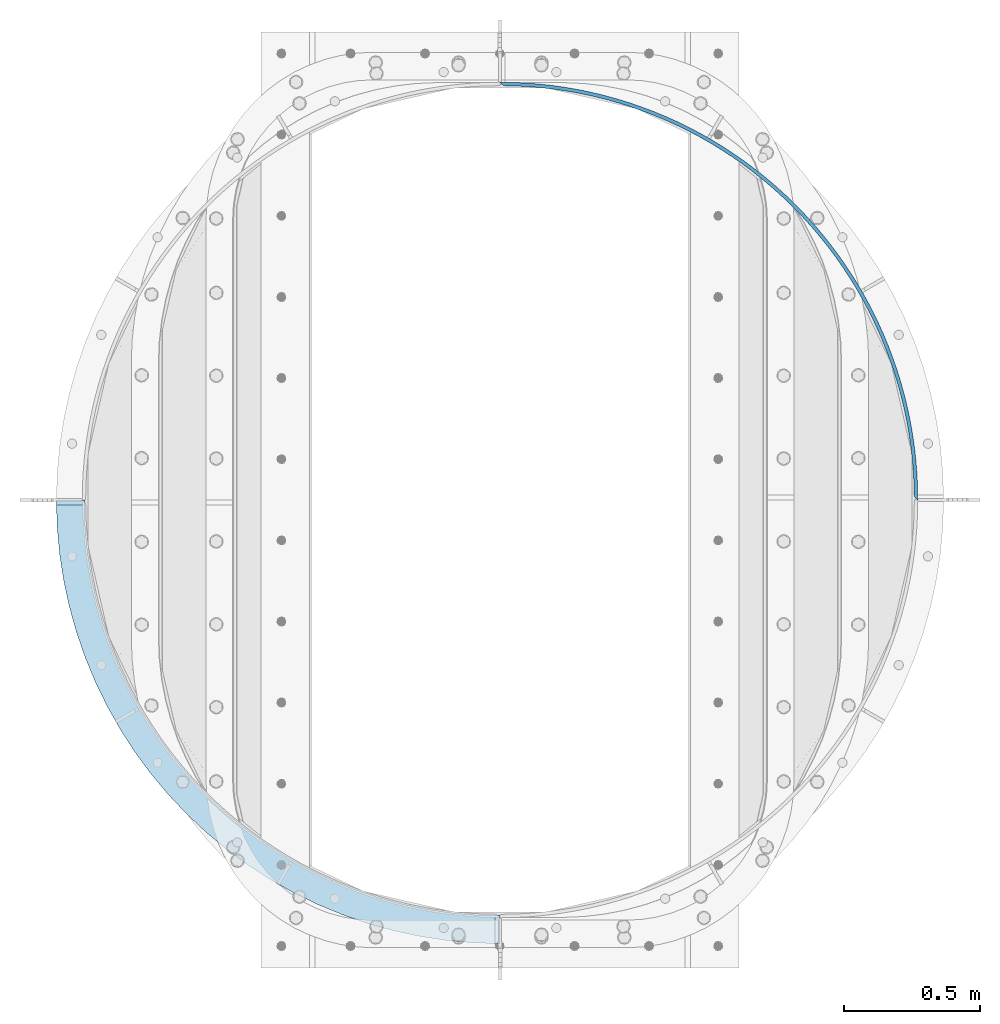
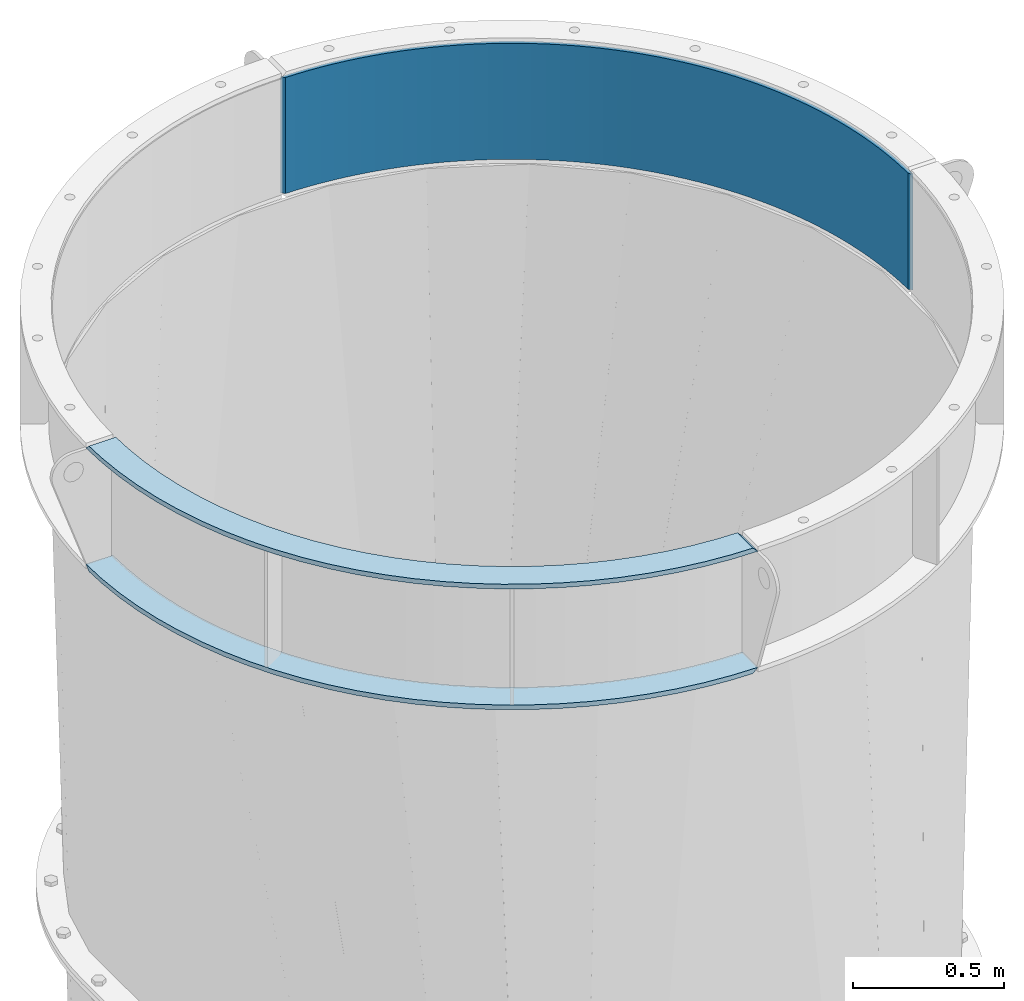
# One storey, part 9 of 15: 2 plates, 1 beam, 1 element without a shape of its own.
"""IFC2X3 building model written with IfcOpenShell, lengths in millimetres."""

from ifc_helpers import new_model, si_unit, frame, origin_with_axes, place, context, subcontext, project, spatial, faceted_brep, material, type_object, element, aggregate, save


model = new_model("IFC2X3")

# Units and contexts
model_context = context("Model", 3, precision=1e-05, world=origin_with_axes())
body_context = subcontext(model_context, "Body", "Model", "MODEL_VIEW")
ifc_project = project(units=[si_unit("LENGTHUNIT", "METRE", prefix="MILLI"), si_unit("AREAUNIT", "SQUARE_METRE"), si_unit("VOLUMEUNIT", "CUBIC_METRE"), si_unit("MASSUNIT", "GRAM", prefix="KILO"), si_unit("TIMEUNIT", "SECOND"), si_unit("PLANEANGLEUNIT", "RADIAN"), si_unit("SOLIDANGLEUNIT", "STERADIAN"), si_unit("THERMODYNAMICTEMPERATUREUNIT", "DEGREE_CELSIUS"), si_unit("LUMINOUSINTENSITYUNIT", "LUMEN")], contexts=[model_context])

# Site, building, storey
site_placement = place(None, origin_with_axes())
site = spatial("IfcSite", under=ifc_project, at=site_placement, CompositionType="ELEMENT")
building_placement = place(site_placement, origin_with_axes())
building = spatial("IfcBuilding", under=site, at=building_placement, Name="Undefined", CompositionType="ELEMENT")
storey_placement = place(building_placement, origin_with_axes())
storey = spatial("IfcBuildingStorey", under=building, at=storey_placement, Name="Undefined", CompositionType="ELEMENT", Elevation=0.0)

# Assembly, beam, plates
assembly_placement = place(storey_placement, origin_with_axes())
assembly = element("IfcElementAssembly", 1, at=assembly_placement, inside=storey, Name="TRANSITION", AssemblyPlace="NOTDEFINED", PredefinedType="RIGID_FRAME")
ifc_material = material(Name="STEEL/A36")
beam_type = type_object("IfcBeamType", PredefinedType="NOTDEFINED")
beam_placement = place(assembly_placement, frame((879.47500000022, 3251.20000000027, 6518.28), z_axis=(0.0, 0.0, 1.0), x_axis=(0.707106781186548, -0.707106781186548, 0.0)))
beam = element("IfcBeam", 2, at=beam_placement, type_object=beam_type, material=ifc_material, Name="PLATE", context=body_context, shape_type="Brep", body=[
    faceted_brep([(2168.73185323846, 4.4901280603583, 234.95), (2150.63139313598, 4.34796445618963, 234.95), (2150.63139313598, 4.34796445618963, -234.95), (2168.73185323846, 4.4901280603583, -234.95), (13.6103320421265, 4.34796445619054, 234.95), (-4.49012806053565, 4.49012806053361, 234.95), (-4.49012806053565, 4.49012806053361, -234.95), (13.6103320421265, 4.34796445619054, -234.95), (30.1773249082131, 38.0852271696592, 234.95), (30.1773249082131, 38.0852271696592, -234.95), (38.8710731535093, 28.8273256014088, -234.95), (38.8710731535093, 28.8273256014088, 234.95), (65.8829191459708, 70.5748181123124, 234.95), (65.8829191459708, 70.5748181123124, -234.95), (74.2815798355832, 61.0484075280069, -234.95), (74.2815798355832, 61.0484075280069, 234.95), (102.591417542014, 101.92683758475, 234.95), (102.591417542014, 101.92683758475, -234.95), (110.686702211824, 92.1413194014985, -234.95), (110.686702211824, 92.1413194014985, 234.95), (140.266593240295, 132.110344928926, 234.95), (140.266593240295, 132.110344928926, -234.95), (148.05051282169, 122.075376271756, -234.95), (148.05051282169, 122.075376271756, 234.95), (178.871265390981, 161.095552667193, 234.95), (178.871265390981, 161.095552667193, -234.95), (186.336138095097, 150.821036838632, -234.95), (186.336138095097, 150.821036838632, 234.95), (218.367335843456, 188.853855898938, 234.95), (218.367335843456, 188.853855898938, -234.95), (225.50579474218, 178.349932605652, -234.95), (225.50579474218, 178.349932605652, 234.95), (258.715826744602, 215.357860530173, 234.95), (258.715826744602, 215.357860530173, -234.95), (265.520827040837, 204.634895876298, -234.95), (265.520827040837, 204.634895876298, 234.95), (299.876919005232, 240.581410308193, 234.95), (299.876919005232, 240.581410308193, -234.95), (306.341744985264, 229.649986565244, -234.95), (306.341744985264, 229.649986565244, 234.95), (341.809991596724, 264.499612634644, 234.95), (341.809991596724, 264.499612634644, -234.95), (347.928263257818, 253.370517798088, -234.95), (347.928263257818, 253.370517798088, 234.95), (384.473661639071, 287.088863131509, 234.95), (384.473661639071, 287.088863131509, -234.95), (390.239340985765, 275.773080274318, -234.95), (390.239340985765, 275.773080274318, 234.95), (427.825825240789, 308.326868935782, 234.95), (427.825825240789, 308.326868935782, -234.95), (433.233222243668, 296.835565369465, -234.95), (433.233222243668, 296.835565369465, 234.95), (471.823699050373, 328.192670699828, 234.95), (471.823699050373, 328.192670699828, -234.95), (476.867477261437, 316.537186953643, -234.95), (476.867477261437, 316.537186953643, 234.95), (516.423862478301, 346.666663275734, 234.95), (516.423862478301, 346.666663275734, -234.95), (521.099044297397, 334.858501904954, -234.95), (521.099044297397, 334.858501904954, 234.95), (561.582300547911, 363.73061506322, 234.95), (561.582300547911, 363.73061506322, -234.95), (565.884272135028, 351.781429297502, -234.95), (565.884272135028, 351.781429297502, 234.95), (607.254447332874, 379.367686002027, 234.95), (607.254447332874, 379.367686002027, -234.95), (611.178963161437, 367.289268245079, -234.95), (611.178963161437, 367.289268245079, 234.95), (653.395229938378, 393.562444191024, 234.95), (653.395229938378, 393.562444191024, -234.95), (656.938416985078, 381.366714382928, -234.95), (656.938416985078, 381.366714382928, 234.95), (699.959112982635, 406.300881117635, 234.95), (699.959112982635, 406.300881117635, -234.95), (703.11747454963, 393.999874971302, -234.95), (703.11747454963, 393.999874971302, 234.95), (746.900143534807, 417.570425482542, 234.95), (746.900143534807, 417.570425482542, -234.95), (749.670562700545, 405.17628260592, -234.95), (749.670562700545, 405.17628260592, 234.95), (794.171996464998, 427.359955606045, 234.95), (794.171996464998, 427.359955606045, -234.95), (796.551739160238, 414.884907521791, -234.95), (796.551739160238, 414.884907521791, 234.95), (841.728020161566, 435.659810403817, 234.95), (841.728020161566, 435.659810403817, -234.95), (843.714737867578, 423.116168478259, -234.95), (843.714737867578, 423.116168478259, 234.95), (889.52128257063, 442.461798921226, 234.95), (889.52128257063, 442.461798921226, -234.95), (891.113014636898, 429.861942214533, -234.95), (891.113014636898, 429.861942214533, 234.95), (937.504617512343, 447.759208416819, 234.95), (937.504617512343, 447.759208416819, -234.95), (938.699793091489, 435.115571466361, -234.95), (938.699793091489, 435.115571466361, 234.95), (985.630671228216, 451.546810986989, 234.95), (985.630671228216, 451.546810986989, -234.95), (986.42811082624, 438.871871535951, -234.95), (986.42811082624, 438.871871535951, 234.95), (1033.85194911356, 453.820868725281, 234.95), (1033.85194911356, 453.820868725281, -234.95), (1034.25086575385, 441.127135408636, -234.95), (1034.25086575385, 441.127135408636, 234.95), (1082.12086258893, 454.579137411258, 234.95), (1082.12086258893, 454.579137411258, -234.95), (1082.12086258893, 441.879137411258, -234.95), (1082.12086258893, 441.879137411258, 234.95), (1130.3897760643, 453.820868725272, 234.95), (1130.3897760643, 453.820868725272, -234.95), (1129.99085942401, 441.127135408629, -234.95), (1129.99085942401, 441.127135408629, 234.95), (1178.61105394964, 451.546810986973, 234.95), (1178.61105394964, 451.546810986973, -234.95), (1177.81361435162, 438.871871535935, -234.95), (1177.81361435162, 438.871871535935, 234.95), (1226.73710766552, 447.759208416796, 234.95), (1226.73710766552, 447.759208416796, -234.95), (1225.54193208637, 435.115571466338, -234.95), (1225.54193208637, 435.115571466338, 234.95), (1274.72044260723, 442.461798921194, 234.95), (1274.72044260723, 442.461798921194, -234.95), (1273.12871054096, 429.861942214502, -234.95), (1273.12871054096, 429.861942214502, 234.95), (1322.51370501629, 435.659810403778, 234.95), (1322.51370501629, 435.659810403778, -234.95), (1320.52698731028, 423.116168478221, -234.95), (1320.52698731028, 423.116168478221, 234.95), (1370.06972871286, 427.359955605998, 234.95), (1370.06972871286, 427.359955605998, -234.95), (1367.68998601762, 414.884907521745, -234.95), (1367.68998601762, 414.884907521745, 234.95), (1417.34158164306, 417.570425482488, 234.95), (1417.34158164306, 417.570425482488, -234.95), (1414.57116247732, 405.176282605867, -234.95), (1414.57116247732, 405.176282605867, 234.95), (1464.28261219523, 406.300881117574, 234.95), (1464.28261219523, 406.300881117574, -234.95), (1461.12425062824, 393.999874971241, -234.95), (1461.12425062824, 393.999874971241, 234.95), (1510.84649523949, 393.562444190955, 234.95), (1510.84649523949, 393.562444190955, -234.95), (1507.30330819279, 381.36671438286, -234.95), (1507.30330819279, 381.36671438286, 234.95), (1556.98727784499, 379.36768600195, 234.95), (1556.98727784499, 379.36768600195, -234.95), (1553.06276201643, 367.289268245003, -234.95), (1553.06276201643, 367.289268245003, 234.95), (1602.65942462996, 363.730615063135, 234.95), (1602.65942462996, 363.730615063135, -234.95), (1598.35745304285, 351.781429297419, -234.95), (1598.35745304285, 351.781429297419, 234.95), (1647.81786269957, 346.666663275642, 234.95), (1647.81786269957, 346.666663275642, -234.95), (1643.14268088048, 334.858501904863, -234.95), (1643.14268088048, 334.858501904863, 234.95), (1692.4180261275, 328.192670699729, 234.95), (1692.4180261275, 328.192670699729, -234.95), (1687.37424791644, 316.537186953544, -234.95), (1687.37424791644, 316.537186953544, 234.95), (1736.41589993709, 308.326868935676, 234.95), (1736.41589993709, 308.326868935676, -234.95), (1731.00850293421, 296.835565369359, -234.95), (1731.00850293421, 296.835565369359, 234.95), (1779.76806353881, 287.088863131397, 234.95), (1779.76806353881, 287.088863131397, -234.95), (1774.00238419212, 275.773080274206, -234.95), (1774.00238419212, 275.773080274206, 234.95), (1822.43173358116, 264.499612634525, 234.95), (1822.43173358116, 264.499612634525, -234.95), (1816.31346192007, 253.370517797969, -234.95), (1816.31346192007, 253.370517797969, 234.95), (1864.36480617266, 240.581410308067, 234.95), (1864.36480617266, 240.581410308067, -234.95), (1857.89998019263, 229.649986565118, -234.95), (1857.89998019263, 229.649986565118, 234.95), (1905.52589843329, 215.357860530039, 234.95), (1905.52589843329, 215.357860530039, -234.95), (1898.72089813706, 204.634895876166, -234.95), (1898.72089813706, 204.634895876166, 234.95), (1945.87438933444, 188.853855898798, 234.95), (1945.87438933444, 188.853855898798, -234.95), (1938.73593043572, 178.349932605514, -234.95), (1938.73593043572, 178.349932605514, 234.95), (1985.37045978692, 161.095552667047, 234.95), (1985.37045978692, 161.095552667047, -234.95), (1977.90558708281, 150.821036838488, -234.95), (1977.90558708281, 150.821036838488, 234.95), (2023.97513193761, 132.110344928774, 234.95), (2023.97513193761, 132.110344928774, -234.95), (2016.19121235622, 122.075376271606, -234.95), (2016.19121235622, 122.075376271606, 234.95), (2061.6503076359, 101.926837584591, 234.95), (2061.6503076359, 101.926837584591, -234.95), (2053.55502296609, 92.1413194013419, -234.95), (2053.55502296609, 92.1413194013419, 234.95), (2098.35880603195, 70.5748181121483, 234.95), (2098.35880603195, 70.5748181121483, -234.95), (2089.96014534234, 61.0484075278443, -234.95), (2089.96014534234, 61.0484075278443, 234.95), (2134.06440026971, 38.0852271694891, 234.95), (2134.06440026971, 38.0852271694891, -234.95), (2125.37065202442, 28.8273256012403, -234.95), (2125.37065202442, 28.8273256012403, 234.95)], [[[0, 1, 2, 3]], [[4, 5, 6, 7]], [[6, 5, 8, 9]], [[10, 11, 4, 7]], [[9, 8, 12, 13]], [[11, 10, 14, 15]], [[13, 12, 16, 17]], [[15, 14, 18, 19]], [[17, 16, 20, 21]], [[19, 18, 22, 23]], [[21, 20, 24, 25]], [[23, 22, 26, 27]], [[25, 24, 28, 29]], [[27, 26, 30, 31]], [[29, 28, 32, 33]], [[31, 30, 34, 35]], [[33, 32, 36, 37]], [[35, 34, 38, 39]], [[37, 36, 40, 41]], [[39, 38, 42, 43]], [[41, 40, 44, 45]], [[43, 42, 46, 47]], [[45, 44, 48, 49]], [[47, 46, 50, 51]], [[49, 48, 52, 53]], [[51, 50, 54, 55]], [[53, 52, 56, 57]], [[55, 54, 58, 59]], [[57, 56, 60, 61]], [[59, 58, 62, 63]], [[61, 60, 64, 65]], [[63, 62, 66, 67]], [[65, 64, 68, 69]], [[67, 66, 70, 71]], [[69, 68, 72, 73]], [[71, 70, 74, 75]], [[73, 72, 76, 77]], [[75, 74, 78, 79]], [[77, 76, 80, 81]], [[79, 78, 82, 83]], [[81, 80, 84, 85]], [[83, 82, 86, 87]], [[85, 84, 88, 89]], [[87, 86, 90, 91]], [[89, 88, 92, 93]], [[91, 90, 94, 95]], [[93, 92, 96, 97]], [[95, 94, 98, 99]], [[97, 96, 100, 101]], [[99, 98, 102, 103]], [[101, 100, 104, 105]], [[103, 102, 106, 107]], [[105, 104, 108, 109]], [[107, 106, 110, 111]], [[109, 108, 112, 113]], [[111, 110, 114, 115]], [[113, 112, 116, 117]], [[115, 114, 118, 119]], [[117, 116, 120, 121]], [[119, 118, 122, 123]], [[121, 120, 124, 125]], [[123, 122, 126, 127]], [[125, 124, 128, 129]], [[127, 126, 130, 131]], [[129, 128, 132, 133]], [[131, 130, 134, 135]], [[133, 132, 136, 137]], [[135, 134, 138, 139]], [[137, 136, 140, 141]], [[139, 138, 142, 143]], [[141, 140, 144, 145]], [[143, 142, 146, 147]], [[145, 144, 148, 149]], [[147, 146, 150, 151]], [[149, 148, 152, 153]], [[151, 150, 154, 155]], [[153, 152, 156, 157]], [[155, 154, 158, 159]], [[157, 156, 160, 161]], [[159, 158, 162, 163]], [[161, 160, 164, 165]], [[163, 162, 166, 167]], [[165, 164, 168, 169]], [[167, 166, 170, 171]], [[169, 168, 172, 173]], [[171, 170, 174, 175]], [[173, 172, 176, 177]], [[175, 174, 178, 179]], [[177, 176, 180, 181]], [[179, 178, 182, 183]], [[181, 180, 184, 185]], [[183, 182, 186, 187]], [[185, 184, 188, 189]], [[187, 186, 190, 191]], [[189, 188, 192, 193]], [[191, 190, 194, 195]], [[193, 192, 196, 197]], [[195, 194, 198, 199]], [[197, 196, 200, 201]], [[199, 198, 202, 203]], [[201, 200, 0, 3]], [[200, 196, 192, 188, 184, 180, 176, 172, 168, 164, 160, 156, 152, 148, 144, 140, 136, 132, 128, 124, 120, 116, 112, 108, 104, 100, 96, 92, 88, 84, 80, 76, 72, 68, 64, 60, 56, 52, 48, 44, 40, 36, 32, 28, 24, 20, 16, 12, 8, 5, 4, 11, 15, 19, 23, 27, 31, 35, 39, 43, 47, 51, 55, 59, 63, 67, 71, 75, 79, 83, 87, 91, 95, 99, 103, 107, 111, 115, 119, 123, 127, 131, 135, 139, 143, 147, 151, 155, 159, 163, 167, 171, 175, 179, 183, 187, 191, 195, 199, 203, 1, 0]], [[203, 202, 2, 1]], [[202, 198, 194, 190, 186, 182, 178, 174, 170, 166, 162, 158, 154, 150, 146, 142, 138, 134, 130, 126, 122, 118, 114, 110, 106, 102, 98, 94, 90, 86, 82, 78, 74, 70, 66, 62, 58, 54, 50, 46, 42, 38, 34, 30, 26, 22, 18, 14, 10, 7, 6, 9, 13, 17, 21, 25, 29, 33, 37, 41, 45, 49, 53, 57, 61, 65, 69, 73, 77, 81, 85, 89, 93, 97, 101, 105, 109, 113, 117, 121, 125, 129, 133, 137, 141, 145, 149, 153, 157, 161, 165, 169, 173, 177, 181, 185, 189, 193, 197, 201, 3, 2]]]),
])
plate_type = type_object("IfcPlateType", PredefinedType="NOTDEFINED")
plate_1_placement = place(assembly_placement, frame((879.474999999729, 88.9000488281254, 6762.755), z_axis=(-1.0, 0.0, 0.0), x_axis=(0.0, 1.0, 0.0)))
plate_1 = element("IfcPlate", 3, at=plate_1_placement, type_object=plate_type, material=ifc_material, Name="PLATE", context=body_context, shape_type="Brep", body=[
    faceted_brep([(1631.94995117188, 9.52499999999964, 1631.94995117188), (1612.89995117188, -9.52499999999964, 1631.37432081696), (1612.89995117188, -9.52499999999964, 1528.18682067481), (1631.94995117188, 9.52499999999964, 1528.76245117188), (103.1875, 9.52499999999964, 0.0), (103.76313049706, -9.52499999999964, 19.05), (0.57563035489018, -9.52499999999964, 19.05), (0.0, 9.52499999999964, 0.0), (2.97740452312382, -9.52499999999964, 98.5346858164392), (2.97740452312382, 9.52499999999964, 98.5346858164392), (11.8987531805783, -9.52499999999964, 196.709829232645), (11.8987531805783, 9.52499999999964, 196.709829232645), (26.7314929387344, -9.52499999999964, 294.167199800127), (26.7314929387344, 9.52499999999964, 294.167199800127), (47.4215007392556, -9.52499999999964, 390.55118614576), (47.4215007392556, 9.52499999999964, 390.55118614576), (73.8932809881087, -9.52499999999964, 485.510093559006), (73.8932809881087, 9.52499999999964, 485.510093559006), (106.050241030797, -9.52499999999964, 578.697427287759), (106.050241030797, 9.52499999999964, 578.697427287759), (143.77504360848, -9.52499999999964, 669.77315686011), (143.77504360848, 9.52499999999964, 669.77315686011), (186.930035008899, -9.52499999999964, 758.404956818652), (186.930035008899, 9.52499999999964, 758.404956818652), (235.357747349844, -9.52499999999964, 844.269419340023), (235.357747349844, 9.52499999999964, 844.269419340023), (288.881473162371, -9.52499999999964, 927.053234314973), (288.881473162371, 9.52499999999964, 927.053234314973), (347.30591017719, -9.52499999999964, 1006.45433258296), (347.30591017719, 9.52499999999964, 1006.45433258296), (410.417873961457, -9.52499999999964, 1082.18298814976), (410.417873961457, 9.52499999999964, 1082.18298814976), (477.987075805645, -9.52499999999964, 1153.96287536617), (477.987075805645, 9.52499999999964, 1153.96287536617), (549.766963022063, -9.52499999999964, 1221.53207721036), (549.766963022063, 9.52499999999964, 1221.53207721036), (625.495618588867, -9.52499999999964, 1284.64404099462), (625.495618588867, 9.52499999999964, 1284.64404099462), (704.896716856861, -9.52499999999964, 1343.06847800943), (704.896716856861, 9.52499999999964, 1343.06847800943), (787.680531831816, -9.52499999999964, 1396.59220382195), (787.680531831816, 9.52499999999964, 1396.59220382195), (873.544994353191, -9.52499999999964, 1445.01991616288), (873.544994353191, 9.52499999999964, 1445.01991616288), (962.176794311736, -9.52499999999964, 1488.1749075633), (962.176794311736, 9.52499999999964, 1488.1749075633), (1053.25252388409, -9.52499999999964, 1525.89971014097), (1053.25252388409, 9.52499999999964, 1525.89971014097), (1146.43985761284, -9.52499999999964, 1558.05667018365), (1146.43985761284, 9.52499999999964, 1558.05667018365), (1241.39876502609, -9.52499999999964, 1584.52845043249), (1241.39876502609, 9.52499999999964, 1584.52845043249), (1337.78275137173, -9.52499999999964, 1605.21845823301), (1337.78275137173, 9.52499999999964, 1605.21845823301), (1435.24012193921, -9.52499999999964, 1620.05119799115), (1435.24012193921, 9.52499999999964, 1620.05119799115), (1533.41526535541, -9.52499999999964, 1628.9725466486), (1533.41526535541, 9.52499999999964, 1628.9725466486), (1539.64557176765, -9.52499999999964, 1525.97330598564), (1539.64557176765, 9.52499999999964, 1525.97330598564), (1447.67800108681, -9.52499999999964, 1517.61604978902), (1447.67800108681, 9.52499999999964, 1517.61604978902), (1356.3828188116, -9.52499999999964, 1503.7211773028), (1356.3828188116, 9.52499999999964, 1503.7211773028), (1266.09315115196, -9.52499999999964, 1484.33938940837), (1266.09315115196, 9.52499999999964, 1484.33938940837), (1177.13845530415, -9.52499999999964, 1459.54140814586), (1177.13845530415, 9.52499999999964, 1459.54140814586), (1089.84331729719, -9.52499999999964, 1429.41771865703), (1089.84331729719, 9.52499999999964, 1429.41771865703), (1004.5262676137, -9.52499999999964, 1394.07823901488), (1004.5262676137, 9.52499999999964, 1394.07823901488), (921.498618906718, -9.52499999999964, 1353.65191914449), (921.498618906718, 9.52499999999964, 1353.65191914449), (841.063330053642, -9.52499999999964, 1308.28627029875), (841.063330053642, 9.52499999999964, 1308.28627029875), (763.513900692163, -9.52499999999964, 1258.1468268058), (763.513900692163, 9.52499999999964, 1258.1468268058), (689.133300271954, -9.52499999999964, 1203.41654205227), (689.133300271954, 9.52499999999964, 1203.41654205227), (618.192935529858, -9.52499999999964, 1144.29512090619), (618.192935529858, 9.52499999999964, 1144.29512090619), (550.95166015617, -9.52499999999964, 1080.99829101564), (550.95166015617, 9.52499999999964, 1080.99829101564), (487.654830265622, -9.52499999999964, 1013.75701564195), (487.654830265622, 9.52499999999964, 1013.75701564195), (428.533409119548, -9.52499999999964, 942.816650899848), (428.533409119548, 9.52499999999964, 942.816650899848), (373.80312436602, -9.52499999999964, 868.436050479634), (373.80312436602, 9.52499999999964, 868.436050479634), (323.663680873077, -9.52499999999964, 790.88662111815), (323.663680873077, 9.52499999999964, 790.88662111815), (278.298032027336, -9.52499999999964, 710.451332265068), (278.298032027336, 9.52499999999964, 710.451332265068), (237.871712156949, -9.52499999999964, 627.423683558081), (237.871712156949, 9.52499999999964, 627.423683558081), (202.532232514805, -9.52499999999964, 542.106633874585), (202.532232514805, 9.52499999999964, 542.106633874585), (172.408543025982, -9.52499999999964, 454.811495867622), (172.408543025982, 9.52499999999964, 454.811495867622), (147.610561763468, -9.52499999999964, 365.856800019807), (147.610561763468, 9.52499999999964, 365.856800019807), (128.228773869042, -9.52499999999964, 275.567132360162), (128.228773869042, 9.52499999999964, 275.567132360162), (114.333901382821, -9.52499999999964, 184.271950084946), (114.333901382821, 9.52499999999964, 184.271950084946), (105.976645186203, -9.52499999999964, 92.3043794040959), (105.976645186203, 9.52499999999964, 92.3043794040959)], [[[0, 1, 2, 3]], [[4, 5, 6, 7]], [[8, 9, 7, 6]], [[8, 10, 11, 9]], [[10, 12, 13, 11]], [[12, 14, 15, 13]], [[14, 16, 17, 15]], [[16, 18, 19, 17]], [[18, 20, 21, 19]], [[20, 22, 23, 21]], [[22, 24, 25, 23]], [[24, 26, 27, 25]], [[26, 28, 29, 27]], [[28, 30, 31, 29]], [[30, 32, 33, 31]], [[32, 34, 35, 33]], [[34, 36, 37, 35]], [[36, 38, 39, 37]], [[38, 40, 41, 39]], [[40, 42, 43, 41]], [[42, 44, 45, 43]], [[44, 46, 47, 45]], [[46, 48, 49, 47]], [[48, 50, 51, 49]], [[50, 52, 53, 51]], [[52, 54, 55, 53]], [[54, 56, 57, 55]], [[57, 56, 1, 0]], [[58, 59, 3, 2]], [[58, 60, 61, 59]], [[60, 62, 63, 61]], [[62, 64, 65, 63]], [[64, 66, 67, 65]], [[66, 68, 69, 67]], [[68, 70, 71, 69]], [[70, 72, 73, 71]], [[72, 74, 75, 73]], [[74, 76, 77, 75]], [[76, 78, 79, 77]], [[78, 80, 81, 79]], [[80, 82, 83, 81]], [[82, 84, 85, 83]], [[84, 86, 87, 85]], [[86, 88, 89, 87]], [[88, 90, 91, 89]], [[90, 92, 93, 91]], [[92, 94, 95, 93]], [[94, 96, 97, 95]], [[96, 98, 99, 97]], [[98, 100, 101, 99]], [[100, 102, 103, 101]], [[102, 104, 105, 103]], [[104, 106, 107, 105]], [[107, 106, 5, 4]], [[11, 13, 15, 17, 19, 21, 23, 25, 27, 29, 31, 33, 35, 37, 39, 41, 43, 45, 47, 49, 51, 53, 55, 57, 0, 3, 59, 61, 63, 65, 67, 69, 71, 73, 75, 77, 79, 81, 83, 85, 87, 89, 91, 93, 95, 97, 99, 101, 103, 105, 107, 4, 7, 9]], [[56, 54, 52, 50, 48, 46, 44, 42, 40, 38, 36, 34, 32, 30, 28, 26, 24, 22, 20, 18, 16, 14, 12, 10, 8, 6, 5, 106, 104, 102, 100, 98, 96, 94, 92, 90, 88, 86, 84, 82, 80, 78, 76, 74, 72, 70, 68, 66, 64, 62, 60, 58, 2, 1]]]),
])
plate_2_placement = place(assembly_placement, frame((879.474999999729, 88.9000000002206, 6273.805), z_axis=(-1.0, 0.0, 0.0), x_axis=(0.0, 1.0, 0.0)))
plate_2 = element("IfcPlate", 4, at=plate_2_placement, type_object=plate_type, material=ifc_material, Name="PLATE", context=body_context, shape_type="Brep", body=[
    faceted_brep([(1612.89995117188, 9.52499999999964, 1631.37432081696), (1631.94995117188, -9.52499999999964, 1631.94995117188), (1631.94995117188, -9.52499999999964, 1528.76245117188), (1612.89995117188, 9.52499999999964, 1528.18682067481), (103.76313049706, 9.52499999999964, 19.05), (103.1875, -9.52499999999964, 0.0), (0.0, -9.52499999999964, 0.0), (0.57563035489018, 9.52499999999964, 19.05), (2.97740452312382, -9.52499999999964, 98.5346858164392), (2.97740452312382, 9.52499999999964, 98.5346858164392), (11.8987531805783, -9.52499999999964, 196.709829232645), (11.8987531805783, 9.52499999999964, 196.709829232645), (26.7314929387344, -9.52499999999964, 294.167199800127), (26.7314929387344, 9.52499999999964, 294.167199800127), (47.4215007392556, -9.52499999999964, 390.55118614576), (47.4215007392556, 9.52499999999964, 390.55118614576), (73.8932809881087, -9.52499999999964, 485.510093559006), (73.8932809881087, 9.52499999999964, 485.510093559006), (106.050241030797, -9.52499999999964, 578.697427287759), (106.050241030797, 9.52499999999964, 578.697427287759), (143.77504360848, -9.52499999999964, 669.77315686011), (143.77504360848, 9.52499999999964, 669.77315686011), (186.930035008899, -9.52499999999964, 758.404956818652), (186.930035008899, 9.52499999999964, 758.404956818652), (235.357747349844, -9.52499999999964, 844.269419340023), (235.357747349844, 9.52499999999964, 844.269419340023), (288.881473162371, -9.52499999999964, 927.053234314973), (288.881473162371, 9.52499999999964, 927.053234314973), (347.30591017719, -9.52499999999964, 1006.45433258296), (347.30591017719, 9.52499999999964, 1006.45433258296), (410.417873961457, -9.52499999999964, 1082.18298814976), (410.417873961457, 9.52499999999964, 1082.18298814976), (477.987075805645, -9.52499999999964, 1153.96287536617), (477.987075805645, 9.52499999999964, 1153.96287536617), (549.766963022063, -9.52499999999964, 1221.53207721036), (549.766963022063, 9.52499999999964, 1221.53207721036), (625.495618588867, -9.52499999999964, 1284.64404099462), (625.495618588867, 9.52499999999964, 1284.64404099462), (704.896716856861, -9.52499999999964, 1343.06847800943), (704.896716856861, 9.52499999999964, 1343.06847800943), (787.680531831816, -9.52499999999964, 1396.59220382195), (787.680531831816, 9.52499999999964, 1396.59220382195), (873.544994353191, -9.52499999999964, 1445.01991616288), (873.544994353191, 9.52499999999964, 1445.01991616288), (962.176794311736, -9.52499999999964, 1488.1749075633), (962.176794311736, 9.52499999999964, 1488.1749075633), (1053.25252388409, -9.52499999999964, 1525.89971014097), (1053.25252388409, 9.52499999999964, 1525.89971014097), (1146.43985761284, -9.52499999999964, 1558.05667018365), (1146.43985761284, 9.52499999999964, 1558.05667018365), (1241.39876502609, -9.52499999999964, 1584.52845043249), (1241.39876502609, 9.52499999999964, 1584.52845043249), (1337.78275137173, -9.52499999999964, 1605.21845823301), (1337.78275137173, 9.52499999999964, 1605.21845823301), (1435.24012193921, -9.52499999999964, 1620.05119799115), (1435.24012193921, 9.52499999999964, 1620.05119799115), (1533.41526535541, -9.52499999999964, 1628.9725466486), (1533.41526535541, 9.52499999999964, 1628.9725466486), (1539.64557176765, -9.52499999999964, 1525.97330598564), (1539.64557176765, 9.52499999999964, 1525.97330598564), (1447.67800108681, -9.52499999999964, 1517.61604978902), (1447.67800108681, 9.52499999999964, 1517.61604978902), (1356.3828188116, -9.52499999999964, 1503.7211773028), (1356.3828188116, 9.52499999999964, 1503.7211773028), (1266.09315115196, -9.52499999999964, 1484.33938940837), (1266.09315115196, 9.52499999999964, 1484.33938940837), (1177.13845530415, -9.52499999999964, 1459.54140814586), (1177.13845530415, 9.52499999999964, 1459.54140814586), (1089.84331729719, -9.52499999999964, 1429.41771865703), (1089.84331729719, 9.52499999999964, 1429.41771865703), (1004.5262676137, -9.52499999999964, 1394.07823901488), (1004.5262676137, 9.52499999999964, 1394.07823901488), (921.498618906718, -9.52499999999964, 1353.65191914449), (921.498618906718, 9.52499999999964, 1353.65191914449), (841.063330053642, -9.52499999999964, 1308.28627029875), (841.063330053642, 9.52499999999964, 1308.28627029875), (763.513900692163, -9.52499999999964, 1258.1468268058), (763.513900692163, 9.52499999999964, 1258.1468268058), (689.133300271954, -9.52499999999964, 1203.41654205227), (689.133300271954, 9.52499999999964, 1203.41654205227), (618.192935529858, -9.52499999999964, 1144.29512090619), (618.192935529858, 9.52499999999964, 1144.29512090619), (550.95166015617, -9.52499999999964, 1080.99829101564), (550.95166015617, 9.52499999999964, 1080.99829101564), (487.654830265622, -9.52499999999964, 1013.75701564195), (487.654830265622, 9.52499999999964, 1013.75701564195), (428.533409119548, -9.52499999999964, 942.816650899848), (428.533409119548, 9.52499999999964, 942.816650899848), (373.80312436602, -9.52499999999964, 868.436050479634), (373.80312436602, 9.52499999999964, 868.436050479634), (323.663680873077, -9.52499999999964, 790.88662111815), (323.663680873077, 9.52499999999964, 790.88662111815), (278.298032027336, -9.52499999999964, 710.451332265068), (278.298032027336, 9.52499999999964, 710.451332265068), (237.871712156949, -9.52499999999964, 627.423683558081), (237.871712156949, 9.52499999999964, 627.423683558081), (202.532232514805, -9.52499999999964, 542.106633874585), (202.532232514805, 9.52499999999964, 542.106633874585), (172.408543025982, -9.52499999999964, 454.811495867622), (172.408543025982, 9.52499999999964, 454.811495867622), (147.610561763468, -9.52499999999964, 365.856800019807), (147.610561763468, 9.52499999999964, 365.856800019807), (128.228773869042, -9.52499999999964, 275.567132360162), (128.228773869042, 9.52499999999964, 275.567132360162), (114.333901382821, -9.52499999999964, 184.271950084946), (114.333901382821, 9.52499999999964, 184.271950084946), (105.976645186203, -9.52499999999964, 92.3043794040959), (105.976645186203, 9.52499999999964, 92.3043794040959)], [[[0, 1, 2, 3]], [[4, 5, 6, 7]], [[8, 9, 7, 6]], [[8, 10, 11, 9]], [[10, 12, 13, 11]], [[12, 14, 15, 13]], [[14, 16, 17, 15]], [[16, 18, 19, 17]], [[18, 20, 21, 19]], [[20, 22, 23, 21]], [[22, 24, 25, 23]], [[24, 26, 27, 25]], [[26, 28, 29, 27]], [[28, 30, 31, 29]], [[30, 32, 33, 31]], [[32, 34, 35, 33]], [[34, 36, 37, 35]], [[36, 38, 39, 37]], [[38, 40, 41, 39]], [[40, 42, 43, 41]], [[42, 44, 45, 43]], [[44, 46, 47, 45]], [[46, 48, 49, 47]], [[48, 50, 51, 49]], [[50, 52, 53, 51]], [[52, 54, 55, 53]], [[54, 56, 57, 55]], [[57, 56, 1, 0]], [[58, 59, 3, 2]], [[58, 60, 61, 59]], [[60, 62, 63, 61]], [[62, 64, 65, 63]], [[64, 66, 67, 65]], [[66, 68, 69, 67]], [[68, 70, 71, 69]], [[70, 72, 73, 71]], [[72, 74, 75, 73]], [[74, 76, 77, 75]], [[76, 78, 79, 77]], [[78, 80, 81, 79]], [[80, 82, 83, 81]], [[82, 84, 85, 83]], [[84, 86, 87, 85]], [[86, 88, 89, 87]], [[88, 90, 91, 89]], [[90, 92, 93, 91]], [[92, 94, 95, 93]], [[94, 96, 97, 95]], [[96, 98, 99, 97]], [[98, 100, 101, 99]], [[100, 102, 103, 101]], [[102, 104, 105, 103]], [[104, 106, 107, 105]], [[107, 106, 5, 4]], [[59, 61, 63, 65, 67, 69, 71, 73, 75, 77, 79, 81, 83, 85, 87, 89, 91, 93, 95, 97, 99, 101, 103, 105, 107, 4, 7, 9, 11, 13, 15, 17, 19, 21, 23, 25, 27, 29, 31, 33, 35, 37, 39, 41, 43, 45, 47, 49, 51, 53, 55, 57, 0, 3]], [[5, 106, 104, 102, 100, 98, 96, 94, 92, 90, 88, 86, 84, 82, 80, 78, 76, 74, 72, 70, 68, 66, 64, 62, 60, 58, 2, 1, 56, 54, 52, 50, 48, 46, 44, 42, 40, 38, 36, 34, 32, 30, 28, 26, 24, 22, 20, 18, 16, 14, 12, 10, 8, 6]]]),
])
aggregate(assembly, [plate_1, plate_2, beam])

save(model, "model.ifc")
